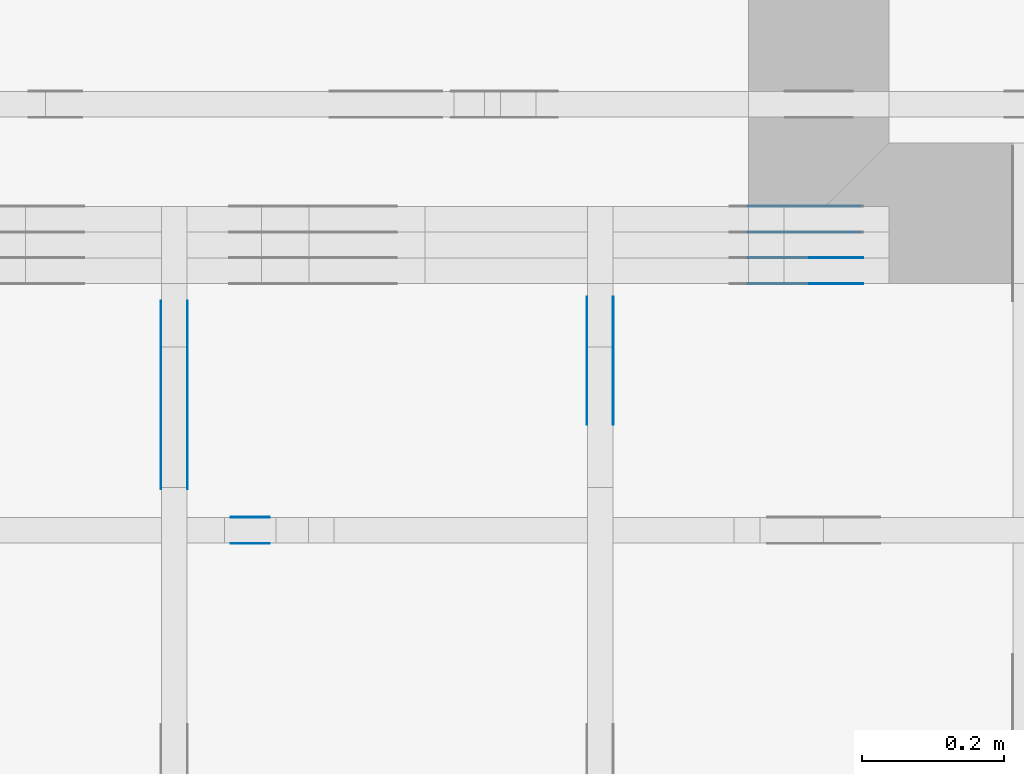
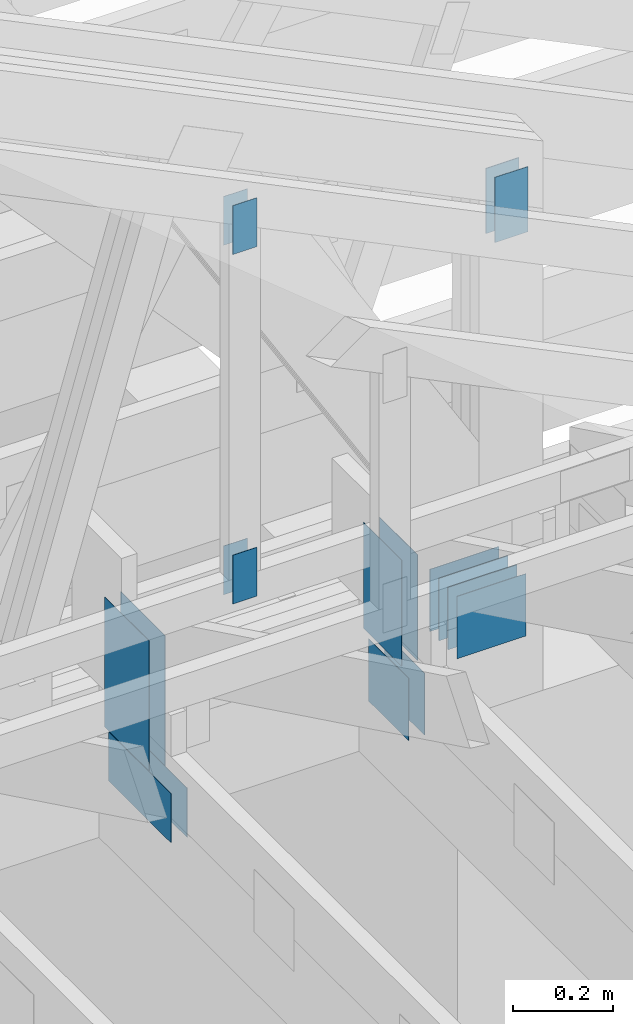
# One storey, part 128 of 159: 21 plates, 4 elements without a shape of their own.
"""IFC2X3 building model written with IfcOpenShell, lengths in millimetres."""

import ifcopenshell
import ifcopenshell.guid

model = None  # the IFC model being written
_history = None  # IfcOwnerHistory: only IFC2X3 demands one
_inside = {}  # id of a spatial element -> (the spatial element, [elements in it])
_under = {}  # id of a project, library or spatial element -> (it, [spatial elements below it])
_declared = {}  # id of a project -> (the project, [libraries it declares])
_typed = {}  # id of a type object -> (the type object, [elements of that type])
_made_of = {}  # id of a material, layer set ... -> (it, [elements and type objects made of it])


def new_model(schema):
    """Start an empty IFC model of exactly this schema.

    Asked for "IFC4X3", IfcOpenShell would pick the latest addendum, in which some entities
    have other attributes; the version numbers below select the first issue.
    IFC2X3 requires an IfcOwnerHistory on every rooted entity: one is made here for all.
    """
    global model, _history
    if schema == "IFC4X3":
        model = ifcopenshell.file(schema_version=(4, 3, 0, 0))
    else:
        model = ifcopenshell.file(schema=schema)
    _inside.clear()
    _under.clear()
    _declared.clear()
    _typed.clear()
    _made_of.clear()
    _history = None
    if model.schema == "IFC2X3":
        org = make("IfcOrganization", Name="unknown")
        user = make(
            "IfcPersonAndOrganization",
            ThePerson=make("IfcPerson", FamilyName="unknown"),
            TheOrganization=org,
        )
        app = make(
            "IfcApplication",
            ApplicationDeveloper=org,
            Version="unknown",
            ApplicationFullName="unknown",
            ApplicationIdentifier="unknown",
        )
        _history = make(
            "IfcOwnerHistory",
            OwningUser=user,
            OwningApplication=app,
            ChangeAction="ADDED",
            CreationDate=0,
        )
    return model


def make(cls, **values):
    """One entity of the class cls with the attributes given. An attribute that is None is left unset."""
    return model.create_entity(
        cls, **{name: value for name, value in values.items() if value is not None}
    )


def rooted(cls, **values):
    """An entity with a GlobalId (a new one), such as an element, a storey or a relation."""
    return make(cls, GlobalId=ifcopenshell.guid.new(), OwnerHistory=_history, **values)


def si_unit(unit_type, name, prefix=None):
    """IfcSIUnit, for example si_unit("LENGTHUNIT", "METRE", prefix="MILLI")."""
    return make("IfcSIUnit", UnitType=unit_type, Prefix=prefix, Name=name)


def assignment(units):
    """IfcUnitAssignment: the units of a project."""
    return None if units is None else make("IfcUnitAssignment", Units=units)


def point(xyz):
    """IfcCartesianPoint."""
    return None if xyz is None else make("IfcCartesianPoint", Coordinates=xyz)


def direction(xyz):
    """IfcDirection."""
    return None if xyz is None else make("IfcDirection", DirectionRatios=xyz)


def frame(location, z_axis=None, x_axis=None):
    """IfcAxis2Placement3D, a coordinate frame: its origin and axes. An axis left out is left unset."""
    return make(
        "IfcAxis2Placement3D",
        Location=point(location),
        Axis=direction(z_axis),
        RefDirection=direction(x_axis),
    )


def frame_2d(location, x_axis=None):
    """IfcAxis2Placement2D, a coordinate frame in the plane: its origin and x axis."""
    return make(
        "IfcAxis2Placement2D", Location=point(location), RefDirection=direction(x_axis)
    )


def origin():
    """The frame at (0, 0, 0) with its axes left unset."""
    return frame((0.0, 0.0, 0.0))


def origin_with_axes():
    """The frame at (0, 0, 0) with the z axis (0, 0, 1) and the x axis (1, 0, 0) written out."""
    return frame((0.0, 0.0, 0.0), z_axis=(0.0, 0.0, 1.0), x_axis=(1.0, 0.0, 0.0))


def origin_2d():
    """The frame at (0, 0) in the plane with its x axis left unset."""
    return frame_2d((0.0, 0.0))


def place(relative_to, where):
    """IfcLocalPlacement: puts the frame where relative to a parent placement (None: the world)."""
    return make(
        "IfcLocalPlacement", PlacementRelTo=relative_to, RelativePlacement=where
    )


def context(
    kind, dimensions, precision=None, world=None, true_north=None, identifier=None
):
    """IfcGeometricRepresentationContext, for example the 3D "Model" context."""
    return make(
        "IfcGeometricRepresentationContext",
        ContextIdentifier=identifier,
        ContextType=kind,
        CoordinateSpaceDimension=dimensions,
        Precision=precision,
        WorldCoordinateSystem=world,
        TrueNorth=true_north,
    )


def project(units=None, contexts=None):
    """IfcProject with its units and contexts."""
    return rooted(
        "IfcProject",
        Name="project",
        RepresentationContexts=contexts,
        UnitsInContext=assignment(units),
    )


def spatial(cls, under=None, at=None, **own):
    """A site, building, storey or space (cls), placed at a placement, below another one or the project."""
    s = rooted(cls, ObjectPlacement=at, **own)
    if under is not None:
        _under.setdefault(under.id(), (under, []))[1].append(s)
    return s


def faces_of(points, faces, orient=None, outer=None):
    """IfcFace entities. A face is a list of loops; a loop is a list of indices into points, from 0.

    orient and outer hold one flag for each loop. By default every Orientation is true, the
    first loop of a face is its IfcFaceOuterBound and the others are IfcFaceBound.
    """
    made = []
    for i, loops in enumerate(faces):
        bounds = []
        for j, loop in enumerate(loops):
            is_outer = j == 0 if outer is None else outer[i][j]
            bounds.append(
                make(
                    "IfcFaceOuterBound" if is_outer else "IfcFaceBound",
                    Bound=make("IfcPolyLoop", Polygon=[points[k] for k in loop]),
                    Orientation=True if orient is None else orient[i][j],
                )
            )
        made.append(make("IfcFace", Bounds=bounds))
    return made


def faceted_brep(points, faces, orient=None, outer=None, voids=None):
    """IfcFacetedBrep: a solid bounded by flat faces; with voids (closed shells), ...WithVoids."""
    shared = [point(p) for p in points]
    hull = make("IfcClosedShell", CfsFaces=faces_of(shared, faces, orient, outer))
    if voids is None:
        return make("IfcFacetedBrep", Outer=hull)
    return make(
        "IfcFacetedBrepWithVoids",
        Outer=hull,
        Voids=[
            make(cls, CfsFaces=faces_of(shared, fs, o, b)) for cls, fs, o, b in voids
        ],
    )


def shape(context_of_items, identifier, shape_type, items):
    """IfcShapeRepresentation: the items that make up one representation, for example the "Body"."""
    return make(
        "IfcShapeRepresentation",
        ContextOfItems=context_of_items,
        RepresentationIdentifier=identifier,
        RepresentationType=shape_type,
        Items=items,
    )


def made_of(thing, what):
    """Note that an element or type object is made of a material, layer set ...; save() writes the relation."""
    if what is not None:
        _made_of.setdefault(what.id(), (what, []))[1].append(thing)
    return thing


def element(
    cls,
    number,
    at=None,
    inside=None,
    cuts=None,
    type_object=None,
    material=None,
    context=None,
    identifier="Body",
    shape_type=None,
    held_by="IfcProductDefinitionShape",
    body=None,
    shapes=None,
    **own,
):
    """One element of the class cls, such as IfcWall. Its Tag is "e" and its number.

    at: its placement. inside: the storey or other place that contains it. cuts: it is an
    opening in that element (IfcRelVoidsElement). A single representation is given by context,
    identifier, shape_type and body (its items); several are given by shapes. held_by: the class
    of the entity that holds the representations. save() writes the other relations.
    """
    e = rooted(cls, Tag="e%d" % number, ObjectPlacement=at, **own)
    if body is not None:
        shapes = [shape(context, identifier, shape_type, body)]
    if shapes is not None:
        e.Representation = make(held_by, Representations=shapes)
    if inside is not None:
        _inside.setdefault(inside.id(), (inside, []))[1].append(e)
    if cuts is not None:
        rooted(
            "IfcRelVoidsElement", RelatingBuildingElement=cuts, RelatedOpeningElement=e
        )
    if type_object is not None:
        _typed.setdefault(type_object.id(), (type_object, []))[1].append(e)
    return made_of(e, material)


def aggregate(whole, parts):
    """IfcRelAggregates: a whole, such as a stair, and the parts it consists of."""
    return rooted("IfcRelAggregates", RelatingObject=whole, RelatedObjects=parts)


def save(model, path):
    """Write the relations noted so far, then the file.

    IfcRelAggregates (storeys below a building ...), IfcRelContainedInSpatialStructure (elements
    in a storey), IfcRelDefinesByType, IfcRelAssociatesMaterial and IfcRelDeclares: one each for
    every whole, place, type object, material and project.
    """
    for whole, parts in _under.values():
        aggregate(whole, parts)
    for where, things in _inside.values():
        rooted(
            "IfcRelContainedInSpatialStructure",
            RelatedElements=things,
            RelatingStructure=where,
        )
    for kind, things in _typed.values():
        rooted("IfcRelDefinesByType", RelatedObjects=things, RelatingType=kind)
    for what, things in _made_of.values():
        rooted("IfcRelAssociatesMaterial", RelatedObjects=things, RelatingMaterial=what)
    for by, libraries in _declared.values():
        rooted("IfcRelDeclares", RelatingContext=by, RelatedDefinitions=libraries)
    model.write(path)


model = new_model("IFC2X3")

# Units and contexts
model_context = context("Model", 3, precision=1e-05, world=origin())
plan_context = context("Plan", 2, precision=1e-05, world=origin_2d())
ifc_project = project(units=[si_unit("LENGTHUNIT", "METRE", prefix="MILLI"), si_unit("AREAUNIT", "SQUARE_METRE"), si_unit("VOLUMEUNIT", "CUBIC_METRE"), si_unit("SOLIDANGLEUNIT", "STERADIAN"), si_unit("PLANEANGLEUNIT", "RADIAN"), si_unit("MASSUNIT", "GRAM"), si_unit("TIMEUNIT", "SECOND"), si_unit("THERMODYNAMICTEMPERATUREUNIT", "DEGREE_CELSIUS"), si_unit("LUMINOUSINTENSITYUNIT", "LUMEN")], contexts=[model_context, plan_context])

# Site, building, storey
site_placement = place(None, origin_with_axes())
site = spatial("IfcSite", under=ifc_project, at=site_placement, CompositionType="ELEMENT")
building_placement = place(site_placement, origin_with_axes())
building = spatial("IfcBuilding", under=site, at=building_placement, Name="Plan 1", CompositionType="ELEMENT")
storey_placement = place(building_placement, origin_with_axes())
storey = spatial("IfcBuildingStorey", under=building, at=storey_placement, Name="Etasje 1", CompositionType="ELEMENT", Elevation=0.0)

# Assembly, plates
assembly_1_placement = place(storey_placement, frame((10700.012663101485, 8801.999999990367, 0.0), z_axis=(0.0, -1.0, 6.123031769111886e-17), x_axis=(1.0, 0.0, 0.0)))
assembly_1 = element("IfcElementAssembly", 1, at=assembly_1_placement, inside=storey, Name="T8 (1)", AssemblyPlace="FACTORY", PredefinedType="TRUSS")
plate_1_placement = place(assembly_1_placement, frame((5960.0, 299.0, 0.0), z_axis=(0.0, 0.0, 1.0), x_axis=(-1.0, 1.2246063538223773e-16, 0.0)))
plate_1 = element("IfcPlate", 2, at=plate_1_placement, Name="GNT100S 152x159", context=model_context, shape_type="Brep", body=[
    faceted_brep([(159.0, 152.0, 1.0), (0.0, 152.0, 1.0), (0.0, 0.0, 1.0), (159.0, 0.0, 1.0), (0.0, 152.0, 0.0), (159.0, 152.0, 1.9471241025775798e-14), (159.0, 5.684341886080802e-14, 1.9471241025775798e-14), (0.0, 5.684341886080802e-14, 0.0), (159.0, 8.447997618295233e-14, 5.2688860062695115e-30), (159.0, 8.454120650064345e-14, 1.0), (1.1247455413666031e-32, 1.1374806803930715e-13, 1.0), (0.0, 1.1368683772161603e-13, 0.0), (159.0, 152.00000000000014, 0.0), (159.0, 152.00000000000014, 1.0), (159.0, 1.7053025658242404e-13, 1.0), (159.0, 1.7053025658242404e-13, 0.0), (0.0, 152.0000000000001, 0.0), (0.0, 152.0000000000001, 1.0), (159.0, 152.00000000000014, 1.0), (159.0, 152.00000000000014, -1.5777218104420236e-30), (1.392216238198645e-29, 1.1368683772161603e-13, -8.524584255963745e-46), (6.123031769113279e-17, 1.1368683772161603e-13, 1.0), (1.8675246895791266e-14, 152.0000000000001, 1.0), (1.8614016578100147e-14, 152.0000000000001, -1.1397421485848253e-30)], [[[0, 1, 2, 3]], [[4, 5, 6, 7]], [[8, 9, 10, 11]], [[12, 13, 14, 15]], [[16, 17, 18, 19]], [[20, 21, 22, 23]]]),
])
plate_2_placement = place(assembly_1_placement, frame((5960.0, 299.0, -37.0), z_axis=(0.0, 0.0, 1.0), x_axis=(-1.0, 1.2246063538223773e-16, 0.0)))
plate_2 = element("IfcPlate", 3, at=plate_2_placement, Name="GNT100S 152x159", context=model_context, shape_type="Brep", body=[
    faceted_brep([(159.0, 152.0, 1.0), (0.0, 152.0, 1.0), (0.0, 0.0, 1.0), (159.0, 0.0, 1.0), (0.0, 152.0, 0.0), (159.0, 152.0, 1.9471241025775798e-14), (159.0, 5.684341886080802e-14, 1.9471241025775798e-14), (0.0, 5.684341886080802e-14, 0.0), (159.0, 8.447997618295233e-14, 5.2688860062695115e-30), (159.0, 8.454120650064345e-14, 1.0), (1.1247455413666031e-32, 1.1374806803930715e-13, 1.0), (0.0, 1.1368683772161603e-13, 0.0), (159.0, 152.00000000000014, 0.0), (159.0, 152.00000000000014, 1.0), (159.0, 1.7053025658242404e-13, 1.0), (159.0, 1.7053025658242404e-13, 0.0), (0.0, 152.0000000000001, 0.0), (0.0, 152.0000000000001, 1.0), (159.0, 152.00000000000014, 1.0), (159.0, 152.00000000000014, -1.5777218104420236e-30), (1.392216238198645e-29, 1.1368683772161603e-13, -8.524584255963745e-46), (6.123031769113279e-17, 1.1368683772161603e-13, 1.0), (1.8675246895791266e-14, 152.0000000000001, 1.0), (1.8614016578100147e-14, 152.0000000000001, -1.1397421485848253e-30)], [[[0, 1, 2, 3]], [[4, 5, 6, 7]], [[8, 9, 10, 11]], [[12, 13, 14, 15]], [[16, 17, 18, 19]], [[20, 21, 22, 23]]]),
])
plate_3_placement = place(assembly_1_placement, frame((5960.0, 299.0, -36.0), z_axis=(0.0, 0.0, 1.0), x_axis=(-1.0, 1.2246063538223773e-16, 0.0)))
plate_3 = element("IfcPlate", 4, at=plate_3_placement, Name="GNT100S 152x159", context=model_context, shape_type="Brep", body=[
    faceted_brep([(159.0, 152.0, 1.0), (0.0, 152.0, 1.0), (0.0, 0.0, 1.0), (159.0, 0.0, 1.0), (0.0, 152.0, 0.0), (159.0, 152.0, 1.9471241025775798e-14), (159.0, 5.684341886080802e-14, 1.9471241025775798e-14), (0.0, 5.684341886080802e-14, 0.0), (159.0, 8.447997618295233e-14, 5.2688860062695115e-30), (159.0, 8.454120650064345e-14, 1.0), (1.1247455413666031e-32, 1.1374806803930715e-13, 1.0), (0.0, 1.1368683772161603e-13, 0.0), (159.0, 152.00000000000014, 0.0), (159.0, 152.00000000000014, 1.0), (159.0, 1.7053025658242404e-13, 1.0), (159.0, 1.7053025658242404e-13, 0.0), (0.0, 152.0000000000001, 0.0), (0.0, 152.0000000000001, 1.0), (159.0, 152.00000000000014, 1.0), (159.0, 152.00000000000014, -1.5777218104420236e-30), (1.392216238198645e-29, 1.1368683772161603e-13, -8.524584255963745e-46), (6.123031769113279e-17, 1.1368683772161603e-13, 1.0), (1.8675246895791266e-14, 152.0000000000001, 1.0), (1.8614016578100147e-14, 152.0000000000001, -1.1397421485848253e-30)], [[[0, 1, 2, 3]], [[4, 5, 6, 7]], [[8, 9, 10, 11]], [[12, 13, 14, 15]], [[16, 17, 18, 19]], [[20, 21, 22, 23]]]),
])
plate_4_placement = place(assembly_1_placement, frame((5960.0, 299.0, -73.0), z_axis=(0.0, 0.0, 1.0), x_axis=(-1.0, 1.2246063538223773e-16, 0.0)))
plate_4 = element("IfcPlate", 5, at=plate_4_placement, Name="GNT100S 152x159", context=model_context, shape_type="Brep", body=[
    faceted_brep([(159.0, 152.0, 1.0), (0.0, 152.0, 1.0), (0.0, 0.0, 1.0), (159.0, 0.0, 1.0), (0.0, 152.0, 0.0), (159.0, 152.0, 1.9471241025775798e-14), (159.0, 5.684341886080802e-14, 1.9471241025775798e-14), (0.0, 5.684341886080802e-14, 0.0), (159.0, 8.447997618295233e-14, 5.2688860062695115e-30), (159.0, 8.454120650064345e-14, 1.0), (1.1247455413666031e-32, 1.1374806803930715e-13, 1.0), (0.0, 1.1368683772161603e-13, 0.0), (159.0, 152.00000000000014, 0.0), (159.0, 152.00000000000014, 1.0), (159.0, 1.7053025658242404e-13, 1.0), (159.0, 1.7053025658242404e-13, 0.0), (0.0, 152.0000000000001, 0.0), (0.0, 152.0000000000001, 1.0), (159.0, 152.00000000000014, 1.0), (159.0, 152.00000000000014, -1.5777218104420236e-30), (1.392216238198645e-29, 1.1368683772161603e-13, -8.524584255963745e-46), (6.123031769113279e-17, 1.1368683772161603e-13, 1.0), (1.8675246895791266e-14, 152.0000000000001, 1.0), (1.8614016578100147e-14, 152.0000000000001, -1.1397421485848253e-30)], [[[0, 1, 2, 3]], [[4, 5, 6, 7]], [[8, 9, 10, 11]], [[12, 13, 14, 15]], [[16, 17, 18, 19]], [[20, 21, 22, 23]]]),
])
plate_5_placement = place(assembly_1_placement, frame((5960.0, 299.0, -72.0), z_axis=(0.0, 0.0, 1.0), x_axis=(-1.0, 1.2246063538223773e-16, 0.0)))
plate_5 = element("IfcPlate", 6, at=plate_5_placement, Name="GNT100S 152x159", context=model_context, shape_type="Brep", body=[
    faceted_brep([(159.0, 152.0, 1.0), (0.0, 152.0, 1.0), (0.0, 0.0, 1.0), (159.0, 0.0, 1.0), (0.0, 152.0, 0.0), (159.0, 152.0, 1.9471241025775798e-14), (159.0, 5.684341886080802e-14, 1.9471241025775798e-14), (0.0, 5.684341886080802e-14, 0.0), (159.0, 8.447997618295233e-14, 5.2688860062695115e-30), (159.0, 8.454120650064345e-14, 1.0), (1.1247455413666031e-32, 1.1374806803930715e-13, 1.0), (0.0, 1.1368683772161603e-13, 0.0), (159.0, 152.00000000000014, 0.0), (159.0, 152.00000000000014, 1.0), (159.0, 1.7053025658242404e-13, 1.0), (159.0, 1.7053025658242404e-13, 0.0), (0.0, 152.0000000000001, 0.0), (0.0, 152.0000000000001, 1.0), (159.0, 152.00000000000014, 1.0), (159.0, 152.00000000000014, -1.5777218104420236e-30), (1.392216238198645e-29, 1.1368683772161603e-13, -8.524584255963745e-46), (6.123031769113279e-17, 1.1368683772161603e-13, 1.0), (1.8675246895791266e-14, 152.0000000000001, 1.0), (1.8614016578100147e-14, 152.0000000000001, -1.1397421485848253e-30)], [[[0, 1, 2, 3]], [[4, 5, 6, 7]], [[8, 9, 10, 11]], [[12, 13, 14, 15]], [[16, 17, 18, 19]], [[20, 21, 22, 23]]]),
])
plate_6_placement = place(assembly_1_placement, frame((5960.0, 299.0, -109.0), z_axis=(0.0, 0.0, 1.0), x_axis=(-1.0, 1.2246063538223773e-16, 0.0)))
plate_6 = element("IfcPlate", 7, at=plate_6_placement, Name="GNT100S 152x159", context=model_context, shape_type="Brep", body=[
    faceted_brep([(159.0, 152.0, 1.0), (0.0, 152.0, 1.0), (0.0, 0.0, 1.0), (159.0, 0.0, 1.0), (0.0, 152.0, 0.0), (159.0, 152.0, 1.9471241025775798e-14), (159.0, 5.684341886080802e-14, 1.9471241025775798e-14), (0.0, 5.684341886080802e-14, 0.0), (159.0, 8.447997618295233e-14, 5.2688860062695115e-30), (159.0, 8.454120650064345e-14, 1.0), (1.1247455413666031e-32, 1.1374806803930715e-13, 1.0), (0.0, 1.1368683772161603e-13, 0.0), (159.0, 152.00000000000014, 0.0), (159.0, 152.00000000000014, 1.0), (159.0, 1.7053025658242404e-13, 1.0), (159.0, 1.7053025658242404e-13, 0.0), (0.0, 152.0000000000001, 0.0), (0.0, 152.0000000000001, 1.0), (159.0, 152.00000000000014, 1.0), (159.0, 152.00000000000014, -1.5777218104420236e-30), (1.392216238198645e-29, 1.1368683772161603e-13, -8.524584255963745e-46), (6.123031769113279e-17, 1.1368683772161603e-13, 1.0), (1.8675246895791266e-14, 152.0000000000001, 1.0), (1.8614016578100147e-14, 152.0000000000001, -1.1397421485848253e-30)], [[[0, 1, 2, 3]], [[4, 5, 6, 7]], [[8, 9, 10, 11]], [[12, 13, 14, 15]], [[16, 17, 18, 19]], [[20, 21, 22, 23]]]),
])
plate_7_placement = place(assembly_1_placement, frame((5888.0, 1290.2585957794156, 0.0), z_axis=(0.0, 0.0, 1.0), x_axis=(6.123031769111886e-17, -1.0, 0.0)))
plate_7 = element("IfcPlate", 8, at=plate_7_placement, Name="GNT100S 76x159", context=model_context, shape_type="Brep", body=[
    faceted_brep([(159.0000508575406, 76.0, 1.0), (5.085754060019099e-05, 76.0, 1.0), (5.085754060019099e-05, 0.0, 1.0), (159.0000508575406, 0.0, 1.0), (5.085754060019099e-05, 76.0, 6.22804673587734e-21), (159.0000508575406, 76.0, 1.9471247253822535e-14), (159.0000508575406, 0.0, 1.9471247253822535e-14), (5.085754060019099e-05, 0.0, 6.22804673587734e-21), (159.0, 3.4557877981217407e-10, 1.788345410772899e-30), (159.0, 3.4557884104249176e-10, 1.0), (1.1247455413666031e-32, 3.456080479040304e-10, 1.0), (0.0, 3.4560798667371273e-10, 0.0), (159.0, 76.00000000034561, 0.0), (159.0, 76.00000000034561, 1.0), (159.0, 3.4560798667371273e-10, 1.0), (159.0, 3.4560798667371273e-10, 0.0), (-2.4308653429145085e-63, 76.00000000034561, 0.0), (-3.7491518045553436e-33, 76.00000000034561, 1.0), (159.0, 76.0000000003456, 1.0), (159.0, 76.0000000003456, -7.888609052210118e-31), (4.232337364123881e-26, 3.4560798667371273e-10, -2.5914736138129785e-42), (6.123031773344224e-17, 3.4560798667371273e-10, 1.0), (9.36823860678351e-15, 76.00000000034561, 1.0), (9.307008289092391e-15, 76.00000000034561, -5.698710742950037e-31)], [[[0, 1, 2, 3]], [[4, 5, 6, 7]], [[8, 9, 10, 11]], [[12, 13, 14, 15]], [[16, 17, 18, 19]], [[20, 21, 22, 23]]]),
])
plate_8_placement = place(assembly_1_placement, frame((5888.0, 1290.2585957794156, -37.0), z_axis=(0.0, 0.0, 1.0), x_axis=(6.123031769111886e-17, -1.0, 0.0)))
plate_8 = element("IfcPlate", 9, at=plate_8_placement, Name="GNT100S 76x159", context=model_context, shape_type="Brep", body=[
    faceted_brep([(159.0000508575406, 76.0, 1.0), (5.085754060019099e-05, 76.0, 1.0), (5.085754060019099e-05, 0.0, 1.0), (159.0000508575406, 0.0, 1.0), (5.085754060019099e-05, 76.0, 6.22804673587734e-21), (159.0000508575406, 76.0, 1.9471247253822535e-14), (159.0000508575406, 0.0, 1.9471247253822535e-14), (5.085754060019099e-05, 0.0, 6.22804673587734e-21), (159.0, 3.4557877981217407e-10, 1.788345410772899e-30), (159.0, 3.4557884104249176e-10, 1.0), (1.1247455413666031e-32, 3.456080479040304e-10, 1.0), (0.0, 3.4560798667371273e-10, 0.0), (159.0, 76.00000000034561, 0.0), (159.0, 76.00000000034561, 1.0), (159.0, 3.4560798667371273e-10, 1.0), (159.0, 3.4560798667371273e-10, 0.0), (-2.4308653429145085e-63, 76.00000000034561, 0.0), (-3.7491518045553436e-33, 76.00000000034561, 1.0), (159.0, 76.0000000003456, 1.0), (159.0, 76.0000000003456, -7.888609052210118e-31), (4.232337364123881e-26, 3.4560798667371273e-10, -2.5914736138129785e-42), (6.123031773344224e-17, 3.4560798667371273e-10, 1.0), (9.36823860678351e-15, 76.00000000034561, 1.0), (9.307008289092391e-15, 76.00000000034561, -5.698710742950037e-31)], [[[0, 1, 2, 3]], [[4, 5, 6, 7]], [[8, 9, 10, 11]], [[12, 13, 14, 15]], [[16, 17, 18, 19]], [[20, 21, 22, 23]]]),
])
plate_9_placement = place(assembly_1_placement, frame((5888.0, 1290.2585957794156, -36.0), z_axis=(0.0, 0.0, 1.0), x_axis=(6.123031769111886e-17, -1.0, 0.0)))
plate_9 = element("IfcPlate", 10, at=plate_9_placement, Name="GNT100S 76x159", context=model_context, shape_type="Brep", body=[
    faceted_brep([(159.0000508575406, 76.0, 1.0), (5.085754060019099e-05, 76.0, 1.0), (5.085754060019099e-05, 0.0, 1.0), (159.0000508575406, 0.0, 1.0), (5.085754060019099e-05, 76.0, 6.22804673587734e-21), (159.0000508575406, 76.0, 1.9471247253822535e-14), (159.0000508575406, 0.0, 1.9471247253822535e-14), (5.085754060019099e-05, 0.0, 6.22804673587734e-21), (159.0, 3.4557877981217407e-10, 1.788345410772899e-30), (159.0, 3.4557884104249176e-10, 1.0), (1.1247455413666031e-32, 3.456080479040304e-10, 1.0), (0.0, 3.4560798667371273e-10, 0.0), (159.0, 76.00000000034561, 0.0), (159.0, 76.00000000034561, 1.0), (159.0, 3.4560798667371273e-10, 1.0), (159.0, 3.4560798667371273e-10, 0.0), (-2.4308653429145085e-63, 76.00000000034561, 0.0), (-3.7491518045553436e-33, 76.00000000034561, 1.0), (159.0, 76.0000000003456, 1.0), (159.0, 76.0000000003456, -7.888609052210118e-31), (4.232337364123881e-26, 3.4560798667371273e-10, -2.5914736138129785e-42), (6.123031773344224e-17, 3.4560798667371273e-10, 1.0), (9.36823860678351e-15, 76.00000000034561, 1.0), (9.307008289092391e-15, 76.00000000034561, -5.698710742950037e-31)], [[[0, 1, 2, 3]], [[4, 5, 6, 7]], [[8, 9, 10, 11]], [[12, 13, 14, 15]], [[16, 17, 18, 19]], [[20, 21, 22, 23]]]),
])
aggregate(assembly_1, [plate_1, plate_2, plate_3, plate_4, plate_5, plate_6, plate_7, plate_8, plate_9])

assembly_2_placement = place(storey_placement, frame((16311.022261404749, -699.9989301294839, 1.1021457184401395e-15), z_axis=(1.0, -6.123031769111886e-17, 6.123031769111886e-17), x_axis=(6.123031769111886e-17, 1.0, 0.0)))
assembly_2 = element("IfcElementAssembly", 11, at=assembly_2_placement, inside=storey, Name="V8 (33)", AssemblyPlace="FACTORY", PredefinedType="TRUSS")
plate_10_placement = place(assembly_2_placement, frame((9461.9990234375, 299.0000000000005, 0.0), z_axis=(0.0, 0.0, 1.0), x_axis=(-1.0, 5.665498452323003e-16, 0.0)))
plate_10 = element("IfcPlate", 12, at=plate_10_placement, Name="GNT100S 152x159", context=model_context, shape_type="Brep", body=[
    faceted_brep([(159.0, 152.00000000000048, 1.0), (0.0, 152.00000000000048, 1.0), (0.0, 5.115907697472721e-13, 1.0), (159.0, 5.115907697472721e-13, 1.0), (0.0, 152.00000000000048, 0.0), (159.0, 152.00000000000048, 1.9471241025775798e-14), (159.0, 5.684341886080801e-13, 1.9471241025775798e-14), (0.0, 5.684341886080801e-13, 0.0), (159.00009331759065, 2.7636573542125095e-14, -1.6921961778782897e-30), (159.00009331759065, 2.7697803859816213e-14, 1.0), (9.331759065389633e-05, 5.690466539847991e-14, 1.0), (9.331759065389633e-05, 5.684343508078879e-14, -9.931545759324813e-37), (159.00009331759065, 152.00000000000003, 0.0), (159.00009331759065, 152.00000000000003, 1.0), (159.00009331759065, 0.0, 1.0), (159.00009331759065, 0.0, 0.0), (9.331759065389633e-05, 152.00000000000003, 0.0), (9.331759065389633e-05, 152.00000000000003, 1.0), (159.00009331759065, 152.00000000000003, 1.0), (159.00009331759065, 152.00000000000003, 0.0), (9.331759065389633e-05, 5.684341886080802e-14, 0.0), (9.331759065395756e-05, 5.684341886080802e-14, 1.0), (9.331759067257158e-05, 152.00000000000003, 1.0), (9.331759067251035e-05, 152.00000000000003, -1.1397420192804459e-30)], [[[0, 1, 2, 3]], [[4, 5, 6, 7]], [[8, 9, 10, 11]], [[12, 13, 14, 15]], [[16, 17, 18, 19]], [[20, 21, 22, 23]]]),
])
plate_11_placement = place(assembly_2_placement, frame((9461.9990234375, 299.0000000000005, -37.0), z_axis=(0.0, 0.0, 1.0), x_axis=(-1.0, 5.665498452323003e-16, 0.0)))
plate_11 = element("IfcPlate", 13, at=plate_11_placement, Name="GNT100S 152x159", context=model_context, shape_type="Brep", body=[
    faceted_brep([(159.0, 152.00000000000048, 1.0), (0.0, 152.00000000000048, 1.0), (0.0, 5.115907697472721e-13, 1.0), (159.0, 5.115907697472721e-13, 1.0), (0.0, 152.00000000000048, 0.0), (159.0, 152.00000000000048, 1.9471241025775798e-14), (159.0, 5.684341886080801e-13, 1.9471241025775798e-14), (0.0, 5.684341886080801e-13, 0.0), (159.00009331759065, 2.7636573542125095e-14, -1.6921961778782897e-30), (159.00009331759065, 2.7697803859816213e-14, 1.0), (9.331759065389633e-05, 5.690466539847991e-14, 1.0), (9.331759065389633e-05, 5.684343508078879e-14, -9.931545759324813e-37), (159.00009331759065, 152.00000000000003, 0.0), (159.00009331759065, 152.00000000000003, 1.0), (159.00009331759065, 0.0, 1.0), (159.00009331759065, 0.0, 0.0), (9.331759065389633e-05, 152.00000000000003, 0.0), (9.331759065389633e-05, 152.00000000000003, 1.0), (159.00009331759065, 152.00000000000003, 1.0), (159.00009331759065, 152.00000000000003, 0.0), (9.331759065389633e-05, 5.684341886080802e-14, 0.0), (9.331759065395756e-05, 5.684341886080802e-14, 1.0), (9.331759067257158e-05, 152.00000000000003, 1.0), (9.331759067251035e-05, 152.00000000000003, -1.1397420192804459e-30)], [[[0, 1, 2, 3]], [[4, 5, 6, 7]], [[8, 9, 10, 11]], [[12, 13, 14, 15]], [[16, 17, 18, 19]], [[20, 21, 22, 23]]]),
])
plate_12_placement = place(assembly_2_placement, frame((9331.054439096797, 570.1817626953125, 0.0), z_axis=(0.0, 0.0, 1.0), x_axis=(5.468420312924882e-14, -1.0, 0.0)))
plate_12 = element("IfcPlate", 14, at=plate_12_placement, Name="GNT100S 152x258", context=model_context, shape_type="Brep", body=[
    faceted_brep([(258.0000305175865, 152.00024840320293, 1.0), (8.29913915367797e-12, 152.00024840320293, 1.0), (0.0, 0.0002484032029315131, 1.0), (258.0000305175782, 0.0002484032029315131, 1.0), (8.29913915367797e-12, 152.00024840320293, 1.0163178538850109e-27), (258.0000305175865, 152.00024840320293, 3.159484766582036e-14), (258.0000305175782, 0.00024840318837959785, 3.159484766581935e-14), (0.0, 0.00024840318837959785, 0.0), (258.00001623924135, -4.739226887592772e-14, 2.901843679375979e-30), (258.00001623924135, -4.73310385582366e-14, 1.0), (1.6239241290350037e-05, 6.122733468940905e-17, 1.0), (1.6239241290350037e-05, -2.9830017098126034e-21, 1.8265014236497646e-37), (258.00001623924135, 152.0, 3.1554436208840472e-30), (258.00001623924135, 152.0, 1.0), (258.00001623924135, 0.0, 1.0), (258.00001623924135, 0.0, 0.0), (1.6239241290350037e-05, 152.0, 0.0), (1.6239241290350037e-05, 152.0, 1.0), (258.0000162392413, 151.99999999999997, 1.0), (258.0000162392413, 151.99999999999997, -1.5777218104420236e-30), (1.6239241290350037e-05, 0.0, 0.0), (1.6239241290411267e-05, -7.498303609110687e-33, 1.0), (1.6239241309025284e-05, 152.0, 1.0), (1.6239241308964054e-05, 152.0, -1.139742207359542e-30)], [[[0, 1, 2, 3]], [[4, 5, 6, 7]], [[8, 9, 10, 11]], [[12, 13, 14, 15]], [[16, 17, 18, 19]], [[20, 21, 22, 23]]]),
])
plate_13_placement = place(assembly_2_placement, frame((9331.054439096797, 570.1817626953125, -37.0), z_axis=(0.0, 0.0, 1.0), x_axis=(5.468420312924882e-14, -1.0, 0.0)))
plate_13 = element("IfcPlate", 15, at=plate_13_placement, Name="GNT100S 152x258", context=model_context, shape_type="Brep", body=[
    faceted_brep([(258.0000305175865, 152.00024840320293, 1.0), (8.29913915367797e-12, 152.00024840320293, 1.0), (0.0, 0.0002484032029315131, 1.0), (258.0000305175782, 0.0002484032029315131, 1.0), (8.29913915367797e-12, 152.00024840320293, 1.0163178538850109e-27), (258.0000305175865, 152.00024840320293, 3.159484766582036e-14), (258.0000305175782, 0.00024840318837959785, 3.159484766581935e-14), (0.0, 0.00024840318837959785, 0.0), (258.00001623924135, -4.739226887592772e-14, 2.901843679375979e-30), (258.00001623924135, -4.73310385582366e-14, 1.0), (1.6239241290350037e-05, 6.122733468940905e-17, 1.0), (1.6239241290350037e-05, -2.9830017098126034e-21, 1.8265014236497646e-37), (258.00001623924135, 152.0, 3.1554436208840472e-30), (258.00001623924135, 152.0, 1.0), (258.00001623924135, 0.0, 1.0), (258.00001623924135, 0.0, 0.0), (1.6239241290350037e-05, 152.0, 0.0), (1.6239241290350037e-05, 152.0, 1.0), (258.0000162392413, 151.99999999999997, 1.0), (258.0000162392413, 151.99999999999997, -1.5777218104420236e-30), (1.6239241290350037e-05, 0.0, 0.0), (1.6239241290411267e-05, -7.498303609110687e-33, 1.0), (1.6239241309025284e-05, 152.0, 1.0), (1.6239241308964054e-05, 152.0, -1.139742207359542e-30)], [[[0, 1, 2, 3]], [[4, 5, 6, 7]], [[8, 9, 10, 11]], [[12, 13, 14, 15]], [[16, 17, 18, 19]], [[20, 21, 22, 23]]]),
])
aggregate(assembly_2, [plate_10, plate_11, plate_12, plate_13])

assembly_3_placement = place(storey_placement, frame((11246.01259527543, 8436.00006782605, 727.7147722720857), z_axis=(0.0, -1.0, 6.123031769111886e-17), x_axis=(1.0, 0.0, 0.0)))
assembly_3 = element("IfcElementAssembly", 16, at=assembly_3_placement, inside=storey, Name="Tr1 (1)", AssemblyPlace="FACTORY", PredefinedType="TRUSS")
plate_14_placement = place(assembly_3_placement, frame((4526.5, 1001.0410386853548, 0.0), z_axis=(0.0, 0.0, 1.0), x_axis=(6.123031769111886e-17, -1.0, 0.0)))
plate_14 = element("IfcPlate", 17, at=plate_14_placement, Name="GNT100S 55x119", context=model_context, shape_type="Brep", body=[
    faceted_brep([(119.0000230603548, 55.0, 1.0), (2.3060354806148098e-05, 55.0, 1.0), (2.3060354806148098e-05, 0.0, 1.0), (119.0000230603548, 0.0, 1.0), (2.3060354806148098e-05, 55.0, 2.8239857017007355e-21), (119.0000230603548, 55.0, 1.457281843447199e-14), (119.0000230603548, 0.0, 1.457281843447199e-14), (2.3060354806148098e-05, 0.0, 2.8239857017007355e-21), (119.0, 6.782605394252235e-05, 1.3384468320270608e-30), (119.0, 6.782605394258358e-05, 1.0), (1.1247455413666031e-32, 6.78260539644428e-05, 1.0), (0.0, 6.782605396438157e-05, 0.0), (119.0, 55.000067826053964, 0.0), (119.0, 55.000067826053964, 1.0), (119.0, 6.782605396438157e-05, 1.0), (119.0, 6.782605396438157e-05, 0.0), (2.4308653429145085e-63, 55.000067826053964, 0.0), (-3.7491518045553436e-33, 55.000067826053964, 1.0), (119.0, 55.00006782605396, 1.0), (119.0, 55.00006782605396, -3.944304526105059e-31), (8.306021663948111e-21, 6.782605396438157e-05, -5.085803452328586e-37), (6.123862371278281e-17, 6.782605396438157e-05, 1.0), (6.796573569735858e-15, 55.000067826053964, 1.0), (6.735343252044739e-15, 55.000067826053964, -4.12407207081433e-31)], [[[0, 1, 2, 3]], [[4, 5, 6, 7]], [[8, 9, 10, 11]], [[12, 13, 14, 15]], [[16, 17, 18, 19]], [[20, 21, 22, 23]]]),
])
plate_15_placement = place(assembly_3_placement, frame((4526.5, 1001.0410386853548, -37.0), z_axis=(0.0, 0.0, 1.0), x_axis=(6.123031769111886e-17, -1.0, 0.0)))
plate_15 = element("IfcPlate", 18, at=plate_15_placement, Name="GNT100S 55x119", context=model_context, shape_type="Brep", body=[
    faceted_brep([(119.0000230603548, 55.0, 1.0), (2.3060354806148098e-05, 55.0, 1.0), (2.3060354806148098e-05, 0.0, 1.0), (119.0000230603548, 0.0, 1.0), (2.3060354806148098e-05, 55.0, 2.8239857017007355e-21), (119.0000230603548, 55.0, 1.457281843447199e-14), (119.0000230603548, 0.0, 1.457281843447199e-14), (2.3060354806148098e-05, 0.0, 2.8239857017007355e-21), (119.0, 6.782605394252235e-05, 1.3384468320270608e-30), (119.0, 6.782605394258358e-05, 1.0), (1.1247455413666031e-32, 6.78260539644428e-05, 1.0), (0.0, 6.782605396438157e-05, 0.0), (119.0, 55.000067826053964, 0.0), (119.0, 55.000067826053964, 1.0), (119.0, 6.782605396438157e-05, 1.0), (119.0, 6.782605396438157e-05, 0.0), (2.4308653429145085e-63, 55.000067826053964, 0.0), (-3.7491518045553436e-33, 55.000067826053964, 1.0), (119.0, 55.00006782605396, 1.0), (119.0, 55.00006782605396, -3.944304526105059e-31), (8.306021663948111e-21, 6.782605396438157e-05, -5.085803452328586e-37), (6.123862371278281e-17, 6.782605396438157e-05, 1.0), (6.796573569735858e-15, 55.000067826053964, 1.0), (6.735343252044739e-15, 55.000067826053964, -4.12407207081433e-31)], [[[0, 1, 2, 3]], [[4, 5, 6, 7]], [[8, 9, 10, 11]], [[12, 13, 14, 15]], [[16, 17, 18, 19]], [[20, 21, 22, 23]]]),
])
plate_16_placement = place(assembly_3_placement, frame((4581.500067826054, 29.720829010009762, 0.0), z_axis=(0.0, 0.0, 1.0), x_axis=(6.123031769111886e-17, 1.0, 0.0)))
plate_16 = element("IfcPlate", 19, at=plate_16_placement, Name="GNT100S 55x119", context=model_context, shape_type="Brep", body=[
    faceted_brep([(118.99999618530273, 55.000067826053964, 1.0), (0.0, 55.000067826053964, 1.0), (3.552713678800501e-15, 6.782605396438157e-05, 1.0), (118.99999618530273, 6.782605396438157e-05, 1.0), (0.0, 55.000067826053964, 0.0), (118.99999618530273, 55.000067826053964, 1.457281514333604e-14), (118.99999618530273, 6.782605396438157e-05, 1.457281514333604e-14), (3.552713678800501e-15, 6.782605396438157e-05, 4.350675744370766e-31), (119.00000002010233, -2.185922341942205e-14, 1.3384471944523577e-30), (119.00000002010233, -2.1797993101730932e-14, 1.0), (2.010233757232527e-08, 6.123031399850132e-17, 1.0), (2.010233757232527e-08, -3.692617547662774e-24, 2.261001455551919e-40), (119.00000002010233, 55.0, 0.0), (119.00000002010233, 55.0, 1.0), (119.00000002010233, 0.0, 1.0), (119.00000002010233, 0.0, 0.0), (2.010233757232527e-08, 55.0, 0.0), (2.010233757232527e-08, 55.0, 1.0), (119.00000002010233, 54.99999999999999, 1.0), (119.00000002010233, 54.99999999999999, -3.944304526105059e-31), (2.010233757232527e-08, 0.0, 0.0), (2.0102337633555586e-08, -7.498303609110687e-33, 1.0), (2.0102344368890532e-08, 55.0, 1.0), (2.0102344307660214e-08, 55.0, -4.124066985010878e-31)], [[[0, 1, 2, 3]], [[4, 5, 6, 7]], [[8, 9, 10, 11]], [[12, 13, 14, 15]], [[16, 17, 18, 19]], [[20, 21, 22, 23]]]),
])
plate_17_placement = place(assembly_3_placement, frame((4581.500067826054, 29.720829010009762, -37.0), z_axis=(0.0, 0.0, 1.0), x_axis=(6.123031769111886e-17, 1.0, 0.0)))
plate_17 = element("IfcPlate", 20, at=plate_17_placement, Name="GNT100S 55x119", context=model_context, shape_type="Brep", body=[
    faceted_brep([(118.99999618530273, 55.000067826053964, 1.0), (0.0, 55.000067826053964, 1.0), (3.552713678800501e-15, 6.782605396438157e-05, 1.0), (118.99999618530273, 6.782605396438157e-05, 1.0), (0.0, 55.000067826053964, 0.0), (118.99999618530273, 55.000067826053964, 1.457281514333604e-14), (118.99999618530273, 6.782605396438157e-05, 1.457281514333604e-14), (3.552713678800501e-15, 6.782605396438157e-05, 4.350675744370766e-31), (119.00000002010233, -2.185922341942205e-14, 1.3384471944523577e-30), (119.00000002010233, -2.1797993101730932e-14, 1.0), (2.010233757232527e-08, 6.123031399850132e-17, 1.0), (2.010233757232527e-08, -3.692617547662774e-24, 2.261001455551919e-40), (119.00000002010233, 55.0, 0.0), (119.00000002010233, 55.0, 1.0), (119.00000002010233, 0.0, 1.0), (119.00000002010233, 0.0, 0.0), (2.010233757232527e-08, 55.0, 0.0), (2.010233757232527e-08, 55.0, 1.0), (119.00000002010233, 54.99999999999999, 1.0), (119.00000002010233, 54.99999999999999, -3.944304526105059e-31), (2.010233757232527e-08, 0.0, 0.0), (2.0102337633555586e-08, -7.498303609110687e-33, 1.0), (2.0102344368890532e-08, 55.0, 1.0), (2.0102344307660214e-08, 55.0, -4.124066985010878e-31)], [[[0, 1, 2, 3]], [[4, 5, 6, 7]], [[8, 9, 10, 11]], [[12, 13, 14, 15]], [[16, 17, 18, 19]], [[20, 21, 22, 23]]]),
])
aggregate(assembly_3, [plate_14, plate_15, plate_16, plate_17])

assembly_4_placement = place(storey_placement, frame((15675.02226140475, -699.9989301294845, 1.1021457184401395e-15), z_axis=(-1.0, 1.836909530733566e-16, 6.123031769111886e-17), x_axis=(-1.836909530733566e-16, -1.0, 0.0)))
assembly_4 = element("IfcElementAssembly", 21, at=assembly_4_placement, inside=storey, Name="T7 (111)", AssemblyPlace="FACTORY", PredefinedType="TRUSS")
plate_18_placement = place(assembly_4_placement, frame((-9477.154435624892, 601.947714222237, 0.0), z_axis=(0.0, 0.0, 1.0), x_axis=(2.6073089813474087e-12, -1.0, 0.0)))
plate_18 = element("IfcPlate", 22, at=plate_18_placement, Name="GNT100S 178x317", context=model_context, shape_type="Brep", body=[
    faceted_brep([(316.9999908340292, 178.00013874989236, 1.0), (2.1351607301767217e-05, 178.00013874989236, 1.0), (2.1351143232095637e-05, 0.00013874989235773683, 1.0), (316.99999083356505, 0.00013874989235773683, 1.0), (2.1351607301767217e-05, 178.00013874989236, 2.61473139660644e-21), (316.9999908340292, 178.00013874989236, 3.882002029369875e-14), (316.99999083356505, 0.0001387490647175582, 3.882002029364191e-14), (2.1351143232095637e-05, 0.0001387490647175582, 2.6146745663395966e-21), (317.00000000000006, -2.1010854189297505e-13, 1.286501276972462e-29), (317.00000000000006, -2.1004731157528393e-13, 1.0), (1.1368683772161603e-13, 1.8190506338635476e-12, 1.0), (1.1368683772161603e-13, 1.8189894035458565e-12, 0.0), (317.00000000000006, 178.0, 0.0), (317.00000000000006, 178.0, 1.0), (317.00000000000006, 0.0, 1.0), (317.00000000000006, 0.0, 0.0), (0.0, 178.00000000000182, 0.0), (0.0, 178.00000000000182, 1.0), (317.00000000000006, 177.99999999999997, 1.0), (317.00000000000006, 177.99999999999997, -1.5777218104420236e-30), (1.1368683772161664e-13, 1.8189894035458565e-12, -3.6433760072445244e-44), (1.1374806803930775e-13, 1.8189894035458565e-12, 1.0), (5.6498181784034924e-14, 178.00000000000182, 1.0), (5.6436951466343805e-14, 178.00000000000182, -3.455652467802488e-30)], [[[0, 1, 2, 3]], [[4, 5, 6, 7]], [[8, 9, 10, 11]], [[12, 13, 14, 15]], [[16, 17, 18, 19]], [[20, 21, 22, 23]]]),
])
plate_19_placement = place(assembly_4_placement, frame((-9477.154435624892, 601.947714222237, -37.0), z_axis=(0.0, 0.0, 1.0), x_axis=(2.6073089813474087e-12, -1.0, 0.0)))
plate_19 = element("IfcPlate", 23, at=plate_19_placement, Name="GNT100S 178x317", context=model_context, shape_type="Brep", body=[
    faceted_brep([(316.9999908340292, 178.00013874989236, 1.0), (2.1351607301767217e-05, 178.00013874989236, 1.0), (2.1351143232095637e-05, 0.00013874989235773683, 1.0), (316.99999083356505, 0.00013874989235773683, 1.0), (2.1351607301767217e-05, 178.00013874989236, 2.61473139660644e-21), (316.9999908340292, 178.00013874989236, 3.882002029369875e-14), (316.99999083356505, 0.0001387490647175582, 3.882002029364191e-14), (2.1351143232095637e-05, 0.0001387490647175582, 2.6146745663395966e-21), (317.00000000000006, -2.1010854189297505e-13, 1.286501276972462e-29), (317.00000000000006, -2.1004731157528393e-13, 1.0), (1.1368683772161603e-13, 1.8190506338635476e-12, 1.0), (1.1368683772161603e-13, 1.8189894035458565e-12, 0.0), (317.00000000000006, 178.0, 0.0), (317.00000000000006, 178.0, 1.0), (317.00000000000006, 0.0, 1.0), (317.00000000000006, 0.0, 0.0), (0.0, 178.00000000000182, 0.0), (0.0, 178.00000000000182, 1.0), (317.00000000000006, 177.99999999999997, 1.0), (317.00000000000006, 177.99999999999997, -1.5777218104420236e-30), (1.1368683772161664e-13, 1.8189894035458565e-12, -3.6433760072445244e-44), (1.1374806803930775e-13, 1.8189894035458565e-12, 1.0), (5.6498181784034924e-14, 178.00000000000182, 1.0), (5.6436951466343805e-14, 178.00000000000182, -3.455652467802488e-30)], [[[0, 1, 2, 3]], [[4, 5, 6, 7]], [[8, 9, 10, 11]], [[12, 13, 14, 15]], [[16, 17, 18, 19]], [[20, 21, 22, 23]]]),
])
plate_20_placement = place(assembly_4_placement, frame((-9461.9990234375, 163.0, 0.0), z_axis=(0.0, 0.0, 1.0), x_axis=(1.0, 0.0, 0.0)))
plate_20 = element("IfcPlate", 24, at=plate_20_placement, context=model_context, shape_type="Brep", body=[
    faceted_brep([(250.0, 120.0, 1.3), (0.0, 120.0, 1.3), (0.0, 0.0, 1.3), (250.0, 0.0, 1.3), (0.0, 120.0, 0.0), (250.0, 120.0, 3.061515884555943e-14), (250.0, 0.0, 3.061515884555943e-14), (0.0, 0.0, 0.0), (250.00009331759065, -4.592275540993631e-14, 2.811864903001948e-30), (250.00009331759065, -4.584315599693786e-14, 1.3), (9.331759065389633e-05, 7.95822714012888e-17, 1.3), (9.331759065389633e-05, -1.714159716572357e-20, 1.0495854401904369e-36), (250.00009331759065, 120.0, 0.0), (250.00009331759065, 120.0, 1.3), (250.00009331759065, 0.0, 1.3), (250.00009331759065, 0.0, 0.0), (9.331759065389633e-05, 120.0, 0.0), (9.331759065389633e-05, 120.0, 1.3), (250.00009331759065, 119.99999999999999, 1.3), (250.00009331759065, 119.99999999999999, -1.5777218104420236e-30), (9.331759065389633e-05, 0.0, 0.0), (9.331759065397593e-05, -9.747794691843893e-33, 1.3), (9.33175906686712e-05, 120.0, 1.3), (9.331759066859161e-05, 120.0, -8.997967269668702e-31)], [[[0, 1, 2, 3]], [[4, 5, 6, 7]], [[8, 9, 10, 11]], [[12, 13, 14, 15]], [[16, 17, 18, 19]], [[20, 21, 22, 23]]]),
])
plate_21_placement = place(assembly_4_placement, frame((-9461.9990234375, 163.0, -37.3), z_axis=(0.0, 0.0, 1.0), x_axis=(1.0, 0.0, 0.0)))
plate_21 = element("IfcPlate", 25, at=plate_21_placement, context=model_context, shape_type="Brep", body=[
    faceted_brep([(250.0, 120.0, 1.2999999999999972), (0.0, 120.0, 1.2999999999999972), (0.0, 0.0, 1.2999999999999972), (250.0, 0.0, 1.2999999999999972), (0.0, 120.0, 0.0), (250.0, 120.0, 3.061515884555943e-14), (250.0, 0.0, 3.061515884555943e-14), (0.0, 0.0, 0.0), (250.00009331759065, -4.592275540993631e-14, 2.811864903001948e-30), (250.00009331759065, -4.584315599693786e-14, 1.2999999999999972), (9.331759065389633e-05, 7.958227140128862e-17, 1.2999999999999972), (9.331759065389633e-05, -1.714159716572357e-20, 1.0495854401904369e-36), (250.00009331759065, 120.0, 0.0), (250.00009331759065, 120.0, 1.2999999999999972), (250.00009331759065, 0.0, 1.2999999999999972), (250.00009331759065, 0.0, 0.0), (9.331759065389633e-05, 120.0, 0.0), (9.331759065389633e-05, 120.0, 1.2999999999999972), (250.00009331759065, 119.99999999999999, 1.2999999999999972), (250.00009331759065, 119.99999999999999, -1.5777218104420236e-30), (9.331759065389633e-05, 0.0, 0.0), (9.331759065397593e-05, -9.747794691843873e-33, 1.2999999999999972), (9.33175906686712e-05, 120.0, 1.2999999999999972), (9.331759066859161e-05, 120.0, -8.997967269668702e-31)], [[[0, 1, 2, 3]], [[4, 5, 6, 7]], [[8, 9, 10, 11]], [[12, 13, 14, 15]], [[16, 17, 18, 19]], [[20, 21, 22, 23]]]),
])
aggregate(assembly_4, [plate_18, plate_19, plate_20, plate_21])

save(model, "model.ifc")
